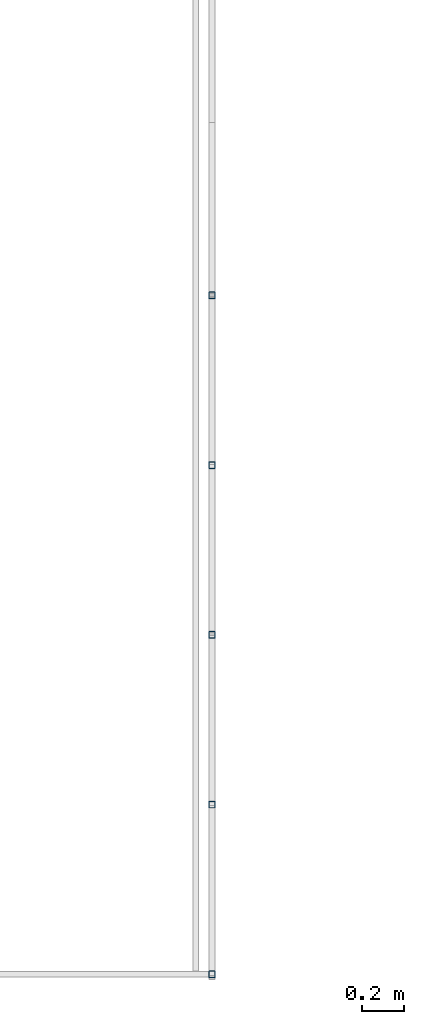
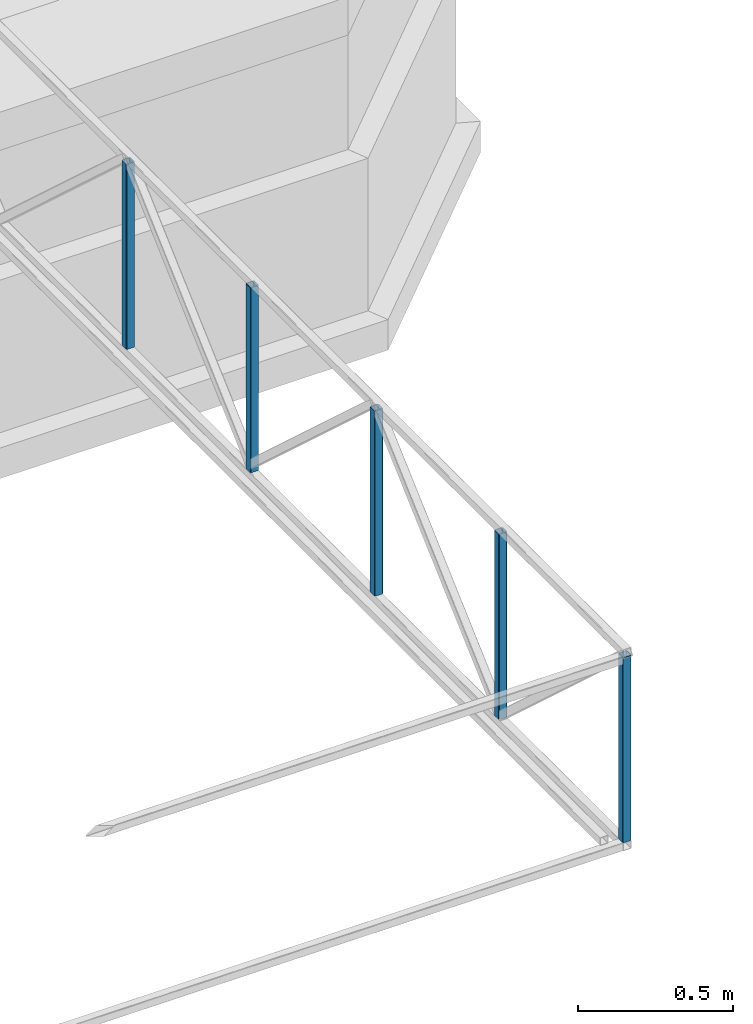
# One storey, part 4 of 7: 5 beams.
"""IFC4X3_ADD2 building model written with IfcOpenShell, lengths in metres."""

from ifc_helpers import new_model, entity, si_unit, converted_unit, frame, origin_with_axes, origin_2d_with_axis, place, context, subcontext, project, spatial, hollow_rectangle, extrude, material, material_profile, profile_set, profile_usage, type_object, element, save


model = new_model("IFC4X3_ADD2")

# Units and contexts
model_context = context("Model", 3, precision=1e-05, world=origin_with_axes())
plan_context = context("Plan", 2, precision=1e-05, world=origin_2d_with_axis())
body_context = subcontext(model_context, "Body", "Model", "MODEL_VIEW")
ifc_project = project(units=[si_unit("VOLUMEUNIT", "CUBIC_METRE"), si_unit("LENGTHUNIT", "METRE"), converted_unit("PLANEANGLEUNIT", "degree", entity("IfcReal", 0.0174532925199433), si_unit("PLANEANGLEUNIT", "RADIAN"), dimensions=[0, 0, 0, 0, 0, 0, 0]), si_unit("AREAUNIT", "SQUARE_METRE")], contexts=[model_context, plan_context])

# Site, building, storey
site_placement = place(None, origin_with_axes())
site = spatial("IfcSite", under=ifc_project, at=site_placement)
building_placement = place(site_placement, origin_with_axes())
building = spatial("IfcBuilding", under=site, at=building_placement, Name="Building")
storey_placement = place(building_placement, frame((0.0, 0.0, -0.870000004768372), z_axis=(0.0, 0.0, 1.0), x_axis=(1.0, 0.0, 0.0)))
storey = spatial("IfcBuildingStorey", under=building, at=storey_placement, Name="Footing")

# Beams
ifc_material = material(Name="Brick")
ifc_material_profile = material_profile(ifc_material, hollow_rectangle(XDim=0.0320000015199184, YDim=0.0320000015199184, WallThickness=0.0020000000949949, InnerFilletRadius=0.0020000000949949, OuterFilletRadius=0.00400000018998981))
ifc_profile_set = profile_set([ifc_material_profile])
ifc_profile_usage_1 = profile_usage(ifc_profile_set, cardinal=5)
beam_type = type_object("IfcBeamType", Name="SHS_0.032x0.032x0", PredefinedType="BEAM", material=ifc_profile_set)
beam_1_placement = place(storey_placement, frame((11.0242557525635, 4.94458627700806, 3.84210193157196), z_axis=(-1.50995830949793e-07, 1.19209246918215e-07, 0.999999999999982), x_axis=(0.999999999999973, 1.74845553146947e-07, 1.50995816738937e-07)))
element("IfcBeam", 1, at=beam_1_placement, inside=storey, type_object=beam_type, material=ifc_profile_usage_1, Name="Beam", context=body_context, shape_type="SweptSolid", body=[
    extrude(hollow_rectangle(XDim=0.0320000015199184, YDim=0.0320000015199184, WallThickness=0.0020000000949949, InnerFilletRadius=0.0020000000949949, OuterFilletRadius=0.00400000018998981), origin_with_axes(), (0.0, 0.0, 1.0), 0.72810028754607),
])
ifc_profile_usage_2 = profile_usage(ifc_profile_set, cardinal=5)
beam_2_placement = place(storey_placement, frame((11.0242557525635, 5.74458646774292, 3.84210193157196), z_axis=(-1.50995816738939e-07, 1.19209246918215e-07, 0.999999999999982), x_axis=(0.999999999999973, 1.74845567357802e-07, 1.50995802528083e-07)))
element("IfcBeam", 2, at=beam_2_placement, inside=storey, type_object=beam_type, material=ifc_profile_usage_2, Name="Beam", context=body_context, shape_type="SweptSolid", body=[
    extrude(hollow_rectangle(XDim=0.0320000015199184, YDim=0.0320000015199184, WallThickness=0.0020000000949949, InnerFilletRadius=0.0020000000949949, OuterFilletRadius=0.00400000018998981), origin_with_axes(), (0.0, 0.0, 1.0), 0.72810028754607),
])
ifc_profile_usage_3 = profile_usage(ifc_profile_set, cardinal=5)
beam_3_placement = place(storey_placement, frame((11.0242547988892, 6.54458618164062, 3.84210169315338), z_axis=(-1.50995816738939e-07, 1.19209246918215e-07, 0.999999999999982), x_axis=(0.999999999999973, 1.74845567357802e-07, 1.50995802528083e-07)))
element("IfcBeam", 3, at=beam_3_placement, inside=storey, type_object=beam_type, material=ifc_profile_usage_3, Name="Beam", context=body_context, shape_type="SweptSolid", body=[
    extrude(hollow_rectangle(XDim=0.0320000015199184, YDim=0.0320000015199184, WallThickness=0.0020000000949949, InnerFilletRadius=0.0020000000949949, OuterFilletRadius=0.00400000018998981), origin_with_axes(), (0.0, 0.0, 1.0), 0.72810028754607),
])
ifc_profile_usage_4 = profile_usage(ifc_profile_set, cardinal=5)
beam_4_placement = place(storey_placement, frame((11.0242547988892, 7.34458637237549, 3.84210169315338), z_axis=(-1.50995816738939e-07, 1.19209246918215e-07, 0.999999999999982), x_axis=(0.999999999999973, 1.74845567357802e-07, 1.50995802528083e-07)))
element("IfcBeam", 4, at=beam_4_placement, inside=storey, type_object=beam_type, material=ifc_profile_usage_4, Name="Beam", context=body_context, shape_type="SweptSolid", body=[
    extrude(hollow_rectangle(XDim=0.0320000015199184, YDim=0.0320000015199184, WallThickness=0.0020000000949949, InnerFilletRadius=0.0020000000949949, OuterFilletRadius=0.00400000018998981), origin_with_axes(), (0.0, 0.0, 1.0), 0.72810028754607),
])
ifc_profile_usage_5 = profile_usage(ifc_profile_set, cardinal=5)
beam_5_placement = place(storey_placement, frame((11.0242547988892, 8.14458656311035, 3.8421014547348), z_axis=(-1.50995816738939e-07, 1.19209246918215e-07, 0.999999999999982), x_axis=(0.999999999999973, 1.74845567357802e-07, 1.50995802528083e-07)))
element("IfcBeam", 5, at=beam_5_placement, inside=storey, type_object=beam_type, material=ifc_profile_usage_5, Name="Beam", context=body_context, shape_type="SweptSolid", body=[
    extrude(hollow_rectangle(XDim=0.0320000015199184, YDim=0.0320000015199184, WallThickness=0.0020000000949949, InnerFilletRadius=0.0020000000949949, OuterFilletRadius=0.00400000018998981), origin_with_axes(), (0.0, 0.0, 1.0), 0.72810028754607),
])

save(model, "model.ifc")
